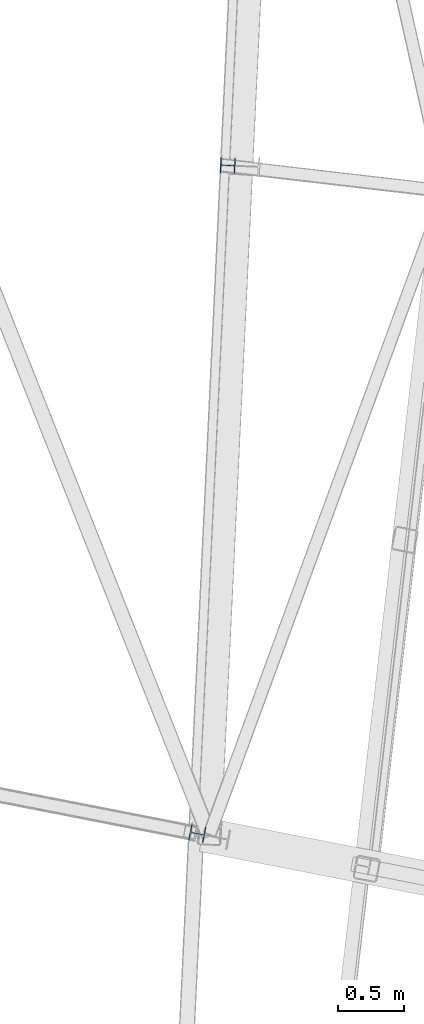
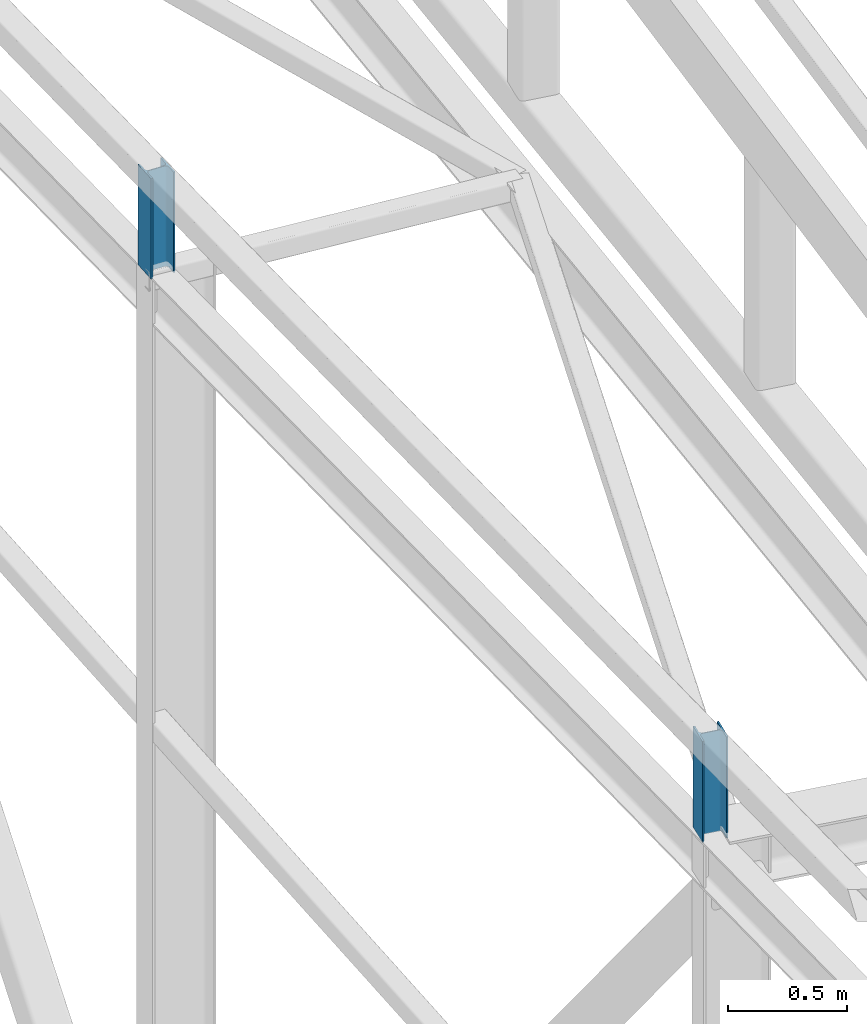
# One storey, part 10 of 215: 2 columns, 2 elements without a shape of their own.
"""IFC2X3 building model written with IfcOpenShell, lengths in millimetres."""

from ifc_helpers import new_model, si_unit, frame, origin_with_axes, origin_2d_with_axis, place, context, subcontext, project, spatial, i_section, extrude, material, type_object, element, aggregate, save


model = new_model("IFC2X3")

# Units and contexts
model_context = context("Model", 3, precision=1e-05, world=origin_with_axes())
body_context = subcontext(model_context, "Body", "Model", "MODEL_VIEW")
ifc_project = project(units=[si_unit("LENGTHUNIT", "METRE", prefix="MILLI"), si_unit("AREAUNIT", "SQUARE_METRE"), si_unit("VOLUMEUNIT", "CUBIC_METRE"), si_unit("MASSUNIT", "GRAM", prefix="KILO"), si_unit("TIMEUNIT", "SECOND"), si_unit("PLANEANGLEUNIT", "RADIAN"), si_unit("SOLIDANGLEUNIT", "STERADIAN"), si_unit("THERMODYNAMICTEMPERATUREUNIT", "DEGREE_CELSIUS"), si_unit("LUMINOUSINTENSITYUNIT", "LUMEN")], contexts=[model_context])

# Site, building, storey
site_placement = place(None, origin_with_axes())
site = spatial("IfcSite", under=ifc_project, at=site_placement, CompositionType="ELEMENT")
building_placement = place(site_placement, origin_with_axes())
building = spatial("IfcBuilding", under=site, at=building_placement, Name="Undefined", CompositionType="ELEMENT")
storey_placement = place(building_placement, origin_with_axes())
storey = spatial("IfcBuildingStorey", under=building, at=storey_placement, Name="Undefined", CompositionType="ELEMENT", Elevation=0.0)

# Assembly, column
assembly_1_placement = place(storey_placement, origin_with_axes())
assembly_1 = element("IfcElementAssembly", 1, at=assembly_1_placement, inside=storey, Name="Steel Assembly", AssemblyPlace="NOTDEFINED", PredefinedType="RIGID_FRAME")
ifc_material = material(Name="STEEL/S275JR")
column_type = type_object("IfcColumnType", Name="HEA120", PredefinedType="NOTDEFINED")
column_1_placement = place(assembly_1_placement, frame((37611.1294440427, 24087.0287486334, 10145.4885382724), z_axis=(0.0, 0.0, 1.0), x_axis=(-0.981422412140383, 0.191859451027444, 0.0)))
column_1 = element("IfcColumn", 2, at=column_1_placement, type_object=column_type, material=ifc_material, ObjectType="HEA120", context=body_context, shape_type="SweptSolid", body=[
    extrude(i_section(OverallWidth=120.0, OverallDepth=114.0, WebThickness=5.0, FlangeThickness=8.0, FilletRadius=12.0, at=origin_2d_with_axis()), frame((0.0, -3.63797880709171e-12, 519.590226729637), z_axis=(0.0, 0.0, -1.0), x_axis=(0.0, 1.0, 0.0)), (0.0, 0.0, 1.0), 519.6),
])
aggregate(assembly_1, [column_1])

assembly_2_placement = place(storey_placement, origin_with_axes())
assembly_2 = element("IfcElementAssembly", 3, at=assembly_2_placement, inside=storey, Name="Steel Assembly", AssemblyPlace="NOTDEFINED", PredefinedType="RIGID_FRAME")
column_2_placement = place(assembly_2_placement, frame((37841.187444159, 29144.7915056933, 9893.68852280575), z_axis=(0.0, 0.0, 1.0), x_axis=(-0.998865584637834, 0.0476187339827342, 0.0)))
column_2 = element("IfcColumn", 4, at=column_2_placement, type_object=column_type, material=ifc_material, ObjectType="HEA120", context=body_context, shape_type="SweptSolid", body=[
    extrude(i_section(OverallWidth=120.0, OverallDepth=114.0, WebThickness=5.0, FlangeThickness=8.0, FilletRadius=12.0, at=origin_2d_with_axis()), frame((0.0, 0.0, 515.821369542433), z_axis=(0.0, 0.0, -1.0), x_axis=(0.0, 1.0, 0.0)), (0.0, 0.0, 1.0), 515.8),
])
aggregate(assembly_2, [column_2])

save(model, "model.ifc")
